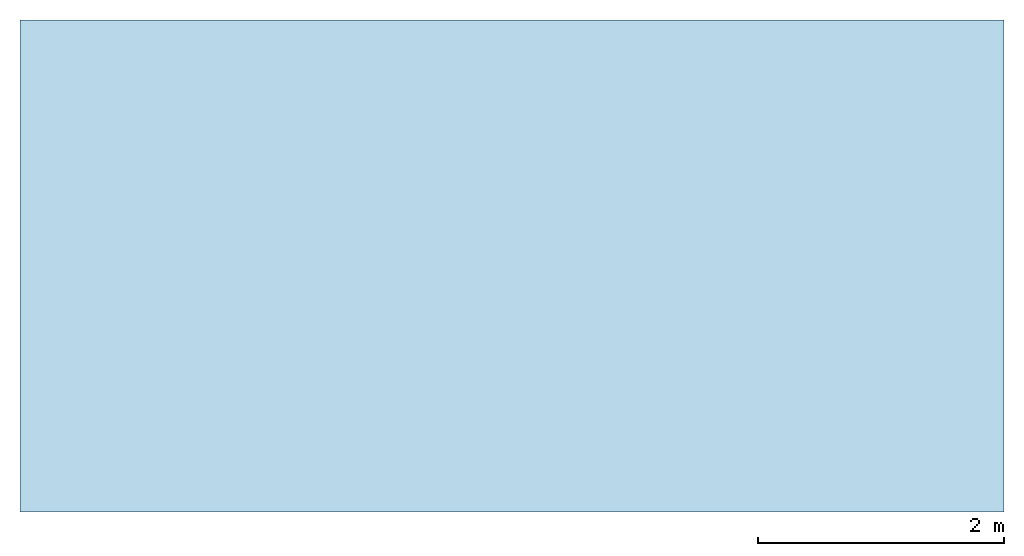
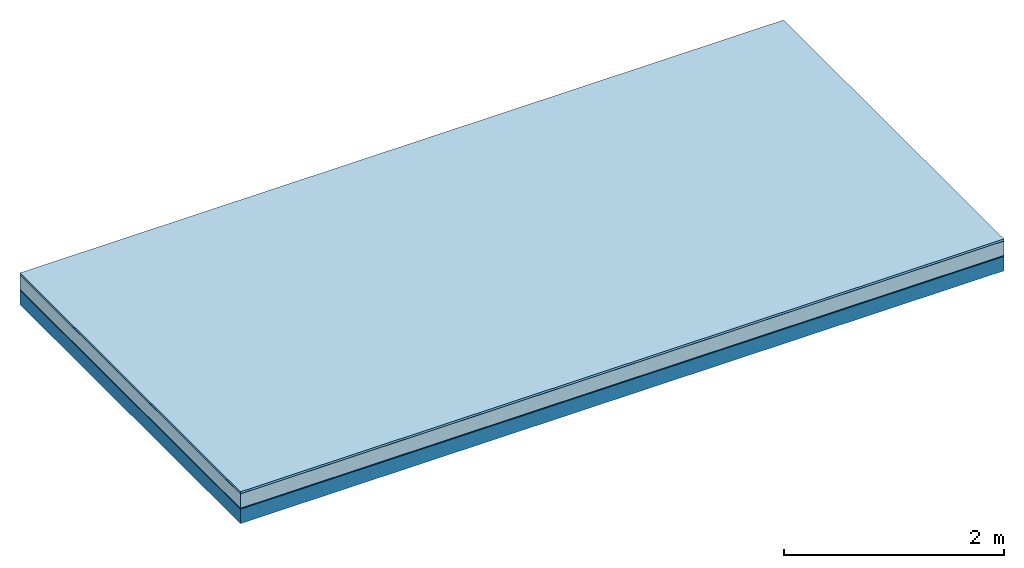
# One storey: 5 plates, 1 member, 1 element without a shape of its own.
"""IFC4 building model written with IfcOpenShell, lengths in metres."""

from ifc_helpers import new_model, si_unit, derived_unit, direction, frame, frame_2d, origin, origin_with_axes, place, context, project, spatial, rectangle, extrude, material, layer, layer_set, type_object, element, aggregate, save


model = new_model("IFC4")

# Units and contexts
plan_context = context("Plan", 3, precision=1e-05, world=origin(), true_north=direction((0.0, 1.0)))
model_context = context("Model", 3, precision=1e-05, world=origin(), true_north=direction((0.0, 1.0)))
ifc_project = project(units=[si_unit("LENGTHUNIT", "METRE"), derived_unit("SOUNDPRESSUREUNIT", [(si_unit("PRESSUREUNIT", "PASCAL", prefix="MICRO"), 0)]), si_unit("ENERGYUNIT", "JOULE", prefix="MEGA"), si_unit("MASSUNIT", "GRAM", prefix="KILO"), derived_unit("THERMALTRANSMITTANCEUNIT", [(si_unit("POWERUNIT", "WATT"), 1), (si_unit("AREAUNIT", "SQUARE_METRE"), -1), (si_unit("THERMODYNAMICTEMPERATUREUNIT", "KELVIN"), -1)]), derived_unit("AREADENSITYUNIT", [(si_unit("MASSUNIT", "GRAM", prefix="KILO"), 1), (si_unit("AREAUNIT", "SQUARE_METRE"), -1)]), derived_unit("USERDEFINED", [(si_unit("ENERGYUNIT", "JOULE", prefix="MEGA"), 1), (si_unit("AREAUNIT", "SQUARE_METRE"), -1)])], contexts=[plan_context, model_context])

# Site, building, storey
site = spatial("IfcSite", under=ifc_project)
building_placement = place(None, origin())
building = spatial("IfcBuilding", under=site, at=building_placement)
storey_placement = place(building_placement, origin())
storey = spatial("IfcBuildingStorey", under=building, at=storey_placement)

# Slab, member, plates
ifc_material_1 = material(Name="with tongue and groove", Category="07.009")
ifc_layer_1 = layer(ifc_material_1, 0.022, Name="Flooring")
ifc_material_2 = material(Category="09.006")
ifc_layer_2 = layer(ifc_material_2, 0.0005, Name="layer")
ifc_material_3 = material(Name="2x 60x80mm")
ifc_layer_3 = layer(ifc_material_3, 0.16, Name="On-material")
ifc_material_4 = material(Name="Wood fiber generic product", Category="10.009")
ifc_layer_4 = layer(ifc_material_4, 0.01, Name="Impact sound insulation")
ifc_material_5 = material(Name="protection", Category="09.007")
ifc_layer_5 = layer(ifc_material_5, 0.0005, Name="Sub-floor")
ifc_material_6 = material(Name="no composite action")
ifc_layer_6 = layer(ifc_material_6, 0.0, Name="Bond")
ifc_layer_7 = layer(None, 0.16, Name="Supporting structure")
ifc_layer_set = layer_set([ifc_layer_1, ifc_layer_2, ifc_layer_3, ifc_layer_4, ifc_layer_5, ifc_layer_6, ifc_layer_7])
slab_type = type_object("IfcSlabType", Name="A2026", PredefinedType="NOTDEFINED", material=ifc_layer_set)
slab_placement = place(None, frame((0.0, 0.0, 0.0), z_axis=(0.0, 0.0, -1.0), x_axis=(1.0, 0.0, 0.0)))
slab = element("IfcSlab", 1, at=slab_placement, inside=storey, type_object=slab_type, material=ifc_layer_set, Name="Slab #1")
ifc_material_7 = material(Name="Solid timber panel")
member_placement = place(slab_placement, origin())
member = element("IfcMember", 2, at=member_placement, material=ifc_material_7, Name="Supporting structure", context=plan_context, shape_type="SweptSolid", body=[
    extrude(rectangle(XDim=1.0, YDim=0.16, at=frame_2d((0.5, 0.08), x_axis=(1.0, 0.0))), frame((0.0, 4.0, 0.193), z_axis=(0.0, -1.0, 0.0), x_axis=(1.0, 0.0, 0.0)), (0.0, 0.0, 1.0), 4.0),
    extrude(rectangle(XDim=1.0, YDim=0.16, at=frame_2d((0.5, 0.08), x_axis=(1.0, 0.0))), frame((1.0, 4.0, 0.193), z_axis=(0.0, -1.0, 0.0), x_axis=(1.0, 0.0, 0.0)), (0.0, 0.0, 1.0), 4.0),
    extrude(rectangle(XDim=1.0, YDim=0.16, at=frame_2d((0.5, 0.08), x_axis=(1.0, 0.0))), frame((2.0, 4.0, 0.193), z_axis=(0.0, -1.0, 0.0), x_axis=(1.0, 0.0, 0.0)), (0.0, 0.0, 1.0), 4.0),
    extrude(rectangle(XDim=1.0, YDim=0.16, at=frame_2d((0.5, 0.08), x_axis=(1.0, 0.0))), frame((3.0, 4.0, 0.193), z_axis=(0.0, -1.0, 0.0), x_axis=(1.0, 0.0, 0.0)), (0.0, 0.0, 1.0), 4.0),
    extrude(rectangle(XDim=1.0, YDim=0.16, at=frame_2d((0.5, 0.08), x_axis=(1.0, 0.0))), frame((4.0, 4.0, 0.193), z_axis=(0.0, -1.0, 0.0), x_axis=(1.0, 0.0, 0.0)), (0.0, 0.0, 1.0), 4.0),
    extrude(rectangle(XDim=1.0, YDim=0.16, at=frame_2d((0.5, 0.08), x_axis=(1.0, 0.0))), frame((5.0, 4.0, 0.193), z_axis=(0.0, -1.0, 0.0), x_axis=(1.0, 0.0, 0.0)), (0.0, 0.0, 1.0), 4.0),
    extrude(rectangle(XDim=1.0, YDim=0.16, at=frame_2d((0.5, 0.08), x_axis=(1.0, 0.0))), frame((6.0, 4.0, 0.193), z_axis=(0.0, -1.0, 0.0), x_axis=(1.0, 0.0, 0.0)), (0.0, 0.0, 1.0), 4.0),
    extrude(rectangle(XDim=1.0, YDim=0.16, at=frame_2d((0.5, 0.08), x_axis=(1.0, 0.0))), frame((7.0, 4.0, 0.193), z_axis=(0.0, -1.0, 0.0), x_axis=(1.0, 0.0, 0.0)), (0.0, 0.0, 1.0), 4.0),
])
plate_1_placement = place(slab_placement, origin())
plate_1 = element("IfcPlate", 3, at=plate_1_placement, material=ifc_material_1, Name="Flooring", context=plan_context, shape_type="SweptSolid", body=[
    extrude(rectangle(XDim=8.0, YDim=4.0, at=frame_2d((4.0, 2.0), x_axis=(1.0, 0.0))), origin_with_axes(), (0.0, 0.0, 1.0), 0.022),
])
plate_2_placement = place(slab_placement, origin())
plate_2 = element("IfcPlate", 4, at=plate_2_placement, material=ifc_material_2, Name="layer", context=plan_context, shape_type="SweptSolid", body=[
    extrude(rectangle(XDim=8.0, YDim=4.0, at=frame_2d((4.0, 2.0), x_axis=(1.0, 0.0))), frame((0.0, 0.0, 0.022), z_axis=(0.0, 0.0, 1.0), x_axis=(1.0, 0.0, 0.0)), (0.0, 0.0, 1.0), 0.0005),
])
plate_3_placement = place(slab_placement, origin())
plate_3 = element("IfcPlate", 5, at=plate_3_placement, material=ifc_material_3, Name="On-material", context=plan_context, shape_type="SweptSolid", body=[
    extrude(rectangle(XDim=8.0, YDim=4.0, at=frame_2d((4.0, 2.0), x_axis=(1.0, 0.0))), frame((0.0, 0.0, 0.0225), z_axis=(0.0, 0.0, 1.0), x_axis=(1.0, 0.0, 0.0)), (0.0, 0.0, 1.0), 0.16),
])
plate_4_placement = place(slab_placement, origin())
plate_4 = element("IfcPlate", 6, at=plate_4_placement, material=ifc_material_4, Name="Impact sound insulation", context=plan_context, shape_type="SweptSolid", body=[
    extrude(rectangle(XDim=8.0, YDim=4.0, at=frame_2d((4.0, 2.0), x_axis=(1.0, 0.0))), frame((0.0, 0.0, 0.1825), z_axis=(0.0, 0.0, 1.0), x_axis=(1.0, 0.0, 0.0)), (0.0, 0.0, 1.0), 0.01),
])
plate_5_placement = place(slab_placement, origin())
plate_5 = element("IfcPlate", 7, at=plate_5_placement, material=ifc_material_5, Name="Sub-floor", context=plan_context, shape_type="SweptSolid", body=[
    extrude(rectangle(XDim=8.0, YDim=4.0, at=frame_2d((4.0, 2.0), x_axis=(1.0, 0.0))), frame((0.0, 0.0, 0.1925), z_axis=(0.0, 0.0, 1.0), x_axis=(1.0, 0.0, 0.0)), (0.0, 0.0, 1.0), 0.0005),
])
aggregate(slab, [plate_1, plate_2, plate_3, plate_4, plate_5, member])

save(model, "model.ifc")
